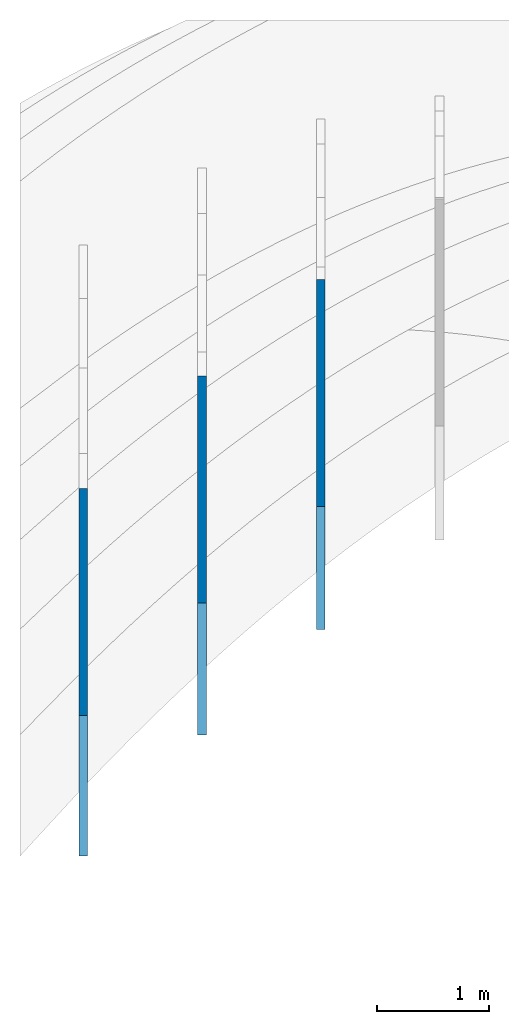
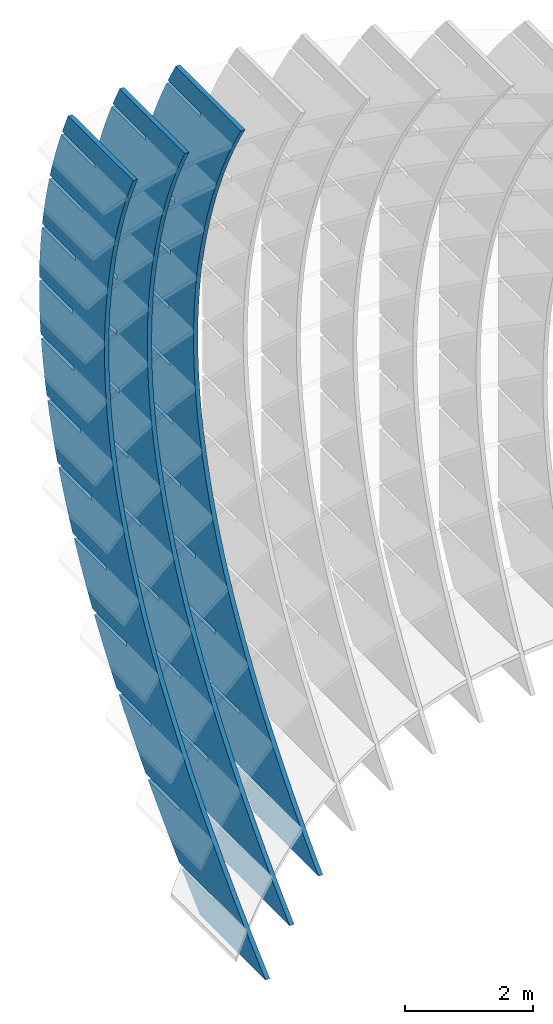
# Not in any storey, part 5 of 9: 3 walls.
"""IFC2X3 building model written with IfcOpenShell, lengths in metres."""

import ifcopenshell
import ifcopenshell.guid

model = None  # the IFC model being written
_history = None  # IfcOwnerHistory: only IFC2X3 demands one
_inside = {}  # id of a spatial element -> (the spatial element, [elements in it])
_under = {}  # id of a project, library or spatial element -> (it, [spatial elements below it])
_declared = {}  # id of a project -> (the project, [libraries it declares])
_typed = {}  # id of a type object -> (the type object, [elements of that type])
_made_of = {}  # id of a material, layer set ... -> (it, [elements and type objects made of it])


def new_model(schema):
    """Start an empty IFC model of exactly this schema.

    Asked for "IFC4X3", IfcOpenShell would pick the latest addendum, in which some entities
    have other attributes; the version numbers below select the first issue.
    IFC2X3 requires an IfcOwnerHistory on every rooted entity: one is made here for all.
    """
    global model, _history
    if schema == "IFC4X3":
        model = ifcopenshell.file(schema_version=(4, 3, 0, 0))
    else:
        model = ifcopenshell.file(schema=schema)
    _inside.clear()
    _under.clear()
    _declared.clear()
    _typed.clear()
    _made_of.clear()
    _history = None
    if model.schema == "IFC2X3":
        org = make("IfcOrganization", Name="unknown")
        user = make(
            "IfcPersonAndOrganization",
            ThePerson=make("IfcPerson", FamilyName="unknown"),
            TheOrganization=org,
        )
        app = make(
            "IfcApplication",
            ApplicationDeveloper=org,
            Version="unknown",
            ApplicationFullName="unknown",
            ApplicationIdentifier="unknown",
        )
        _history = make(
            "IfcOwnerHistory",
            OwningUser=user,
            OwningApplication=app,
            ChangeAction="ADDED",
            CreationDate=0,
        )
    return model


def make(cls, **values):
    """One entity of the class cls with the attributes given. An attribute that is None is left unset."""
    return model.create_entity(
        cls, **{name: value for name, value in values.items() if value is not None}
    )


def rooted(cls, **values):
    """An entity with a GlobalId (a new one), such as an element, a storey or a relation."""
    return make(cls, GlobalId=ifcopenshell.guid.new(), OwnerHistory=_history, **values)


def si_unit(unit_type, name, prefix=None):
    """IfcSIUnit, for example si_unit("LENGTHUNIT", "METRE", prefix="MILLI")."""
    return make("IfcSIUnit", UnitType=unit_type, Prefix=prefix, Name=name)


def assignment(units):
    """IfcUnitAssignment: the units of a project."""
    return None if units is None else make("IfcUnitAssignment", Units=units)


def point(xyz):
    """IfcCartesianPoint."""
    return None if xyz is None else make("IfcCartesianPoint", Coordinates=xyz)


def direction(xyz):
    """IfcDirection."""
    return None if xyz is None else make("IfcDirection", DirectionRatios=xyz)


def frame(location, z_axis=None, x_axis=None):
    """IfcAxis2Placement3D, a coordinate frame: its origin and axes. An axis left out is left unset."""
    return make(
        "IfcAxis2Placement3D",
        Location=point(location),
        Axis=direction(z_axis),
        RefDirection=direction(x_axis),
    )


def frame_2d(location, x_axis=None):
    """IfcAxis2Placement2D, a coordinate frame in the plane: its origin and x axis."""
    return make(
        "IfcAxis2Placement2D", Location=point(location), RefDirection=direction(x_axis)
    )


def origin_with_axes():
    """The frame at (0, 0, 0) with the z axis (0, 0, 1) and the x axis (1, 0, 0) written out."""
    return frame((0.0, 0.0, 0.0), z_axis=(0.0, 0.0, 1.0), x_axis=(1.0, 0.0, 0.0))


def place(relative_to, where):
    """IfcLocalPlacement: puts the frame where relative to a parent placement (None: the world)."""
    return make(
        "IfcLocalPlacement", PlacementRelTo=relative_to, RelativePlacement=where
    )


def context(
    kind, dimensions, precision=None, world=None, true_north=None, identifier=None
):
    """IfcGeometricRepresentationContext, for example the 3D "Model" context."""
    return make(
        "IfcGeometricRepresentationContext",
        ContextIdentifier=identifier,
        ContextType=kind,
        CoordinateSpaceDimension=dimensions,
        Precision=precision,
        WorldCoordinateSystem=world,
        TrueNorth=true_north,
    )


def project(units=None, contexts=None):
    """IfcProject with its units and contexts."""
    return rooted(
        "IfcProject",
        Name="project",
        RepresentationContexts=contexts,
        UnitsInContext=assignment(units),
    )


def spatial(cls, under=None, at=None, **own):
    """A site, building, storey or space (cls), placed at a placement, below another one or the project."""
    s = rooted(cls, ObjectPlacement=at, **own)
    if under is not None:
        _under.setdefault(under.id(), (under, []))[1].append(s)
    return s


def polyline(points):
    """IfcPolyline through the points."""
    return make("IfcPolyline", Points=[point(p) for p in points])


def circle_curve(where, radius):
    """IfcCircle in the frame where."""
    return make("IfcCircle", Position=where, Radius=radius)


def parameter(value):
    """IfcParameterValue: where a trimmed curve begins or ends, as a parameter of its basis curve."""
    return model.create_entity("IfcParameterValue", value)


def trimmed(basis, trim1, trim2, sense, master):
    """IfcTrimmedCurve: the piece of a basis curve between two trims."""
    return make(
        "IfcTrimmedCurve",
        BasisCurve=basis,
        Trim1=trim1,
        Trim2=trim2,
        SenseAgreement=sense,
        MasterRepresentation=master,
    )


def segment(curve, same_sense, transition):
    """IfcCompositeCurveSegment."""
    return make(
        "IfcCompositeCurveSegment",
        Transition=transition,
        SameSense=same_sense,
        ParentCurve=curve,
    )


def composite_curve(segments, self_intersect=None):
    """IfcCompositeCurve: segments joined end to end."""
    return make("IfcCompositeCurve", Segments=segments, SelfIntersect=self_intersect)


def outline(outer, holes=None, kind="AREA"):
    """IfcArbitraryClosedProfileDef: a profile drawn as a closed curve; with holes, ...WithVoids."""
    if holes is None:
        return make("IfcArbitraryClosedProfileDef", ProfileType=kind, OuterCurve=outer)
    return make(
        "IfcArbitraryProfileDefWithVoids",
        ProfileType=kind,
        OuterCurve=outer,
        InnerCurves=holes,
    )


def extrude(swept, where, along, depth):
    """IfcExtrudedAreaSolid: the profile swept, set in the frame where, extruded along a direction by depth."""
    return make(
        "IfcExtrudedAreaSolid",
        SweptArea=swept,
        Position=where,
        ExtrudedDirection=direction(along),
        Depth=depth,
    )


def shape(context_of_items, identifier, shape_type, items):
    """IfcShapeRepresentation: the items that make up one representation, for example the "Body"."""
    return make(
        "IfcShapeRepresentation",
        ContextOfItems=context_of_items,
        RepresentationIdentifier=identifier,
        RepresentationType=shape_type,
        Items=items,
    )


def material(Name=None, Category=None):
    """IfcMaterial."""
    return make("IfcMaterial", Name=Name, Category=Category)


def made_of(thing, what):
    """Note that an element or type object is made of a material, layer set ...; save() writes the relation."""
    if what is not None:
        _made_of.setdefault(what.id(), (what, []))[1].append(thing)
    return thing


def type_object(cls, material=None, **own):
    """A type object (cls), such as IfcWallType, which elements share."""
    return made_of(rooted(cls, **own), material)


def element(
    cls,
    number,
    at=None,
    inside=None,
    cuts=None,
    type_object=None,
    material=None,
    context=None,
    identifier="Body",
    shape_type=None,
    held_by="IfcProductDefinitionShape",
    body=None,
    shapes=None,
    **own,
):
    """One element of the class cls, such as IfcWall. Its Tag is "e" and its number.

    at: its placement. inside: the storey or other place that contains it. cuts: it is an
    opening in that element (IfcRelVoidsElement). A single representation is given by context,
    identifier, shape_type and body (its items); several are given by shapes. held_by: the class
    of the entity that holds the representations. save() writes the other relations.
    """
    e = rooted(cls, Tag="e%d" % number, ObjectPlacement=at, **own)
    if body is not None:
        shapes = [shape(context, identifier, shape_type, body)]
    if shapes is not None:
        e.Representation = make(held_by, Representations=shapes)
    if inside is not None:
        _inside.setdefault(inside.id(), (inside, []))[1].append(e)
    if cuts is not None:
        rooted(
            "IfcRelVoidsElement", RelatingBuildingElement=cuts, RelatedOpeningElement=e
        )
    if type_object is not None:
        _typed.setdefault(type_object.id(), (type_object, []))[1].append(e)
    return made_of(e, material)


def aggregate(whole, parts):
    """IfcRelAggregates: a whole, such as a stair, and the parts it consists of."""
    return rooted("IfcRelAggregates", RelatingObject=whole, RelatedObjects=parts)


def save(model, path):
    """Write the relations noted so far, then the file.

    IfcRelAggregates (storeys below a building ...), IfcRelContainedInSpatialStructure (elements
    in a storey), IfcRelDefinesByType, IfcRelAssociatesMaterial and IfcRelDeclares: one each for
    every whole, place, type object, material and project.
    """
    for whole, parts in _under.values():
        aggregate(whole, parts)
    for where, things in _inside.values():
        rooted(
            "IfcRelContainedInSpatialStructure",
            RelatedElements=things,
            RelatingStructure=where,
        )
    for kind, things in _typed.values():
        rooted("IfcRelDefinesByType", RelatedObjects=things, RelatingType=kind)
    for what, things in _made_of.values():
        rooted("IfcRelAssociatesMaterial", RelatedObjects=things, RelatingMaterial=what)
    for by, libraries in _declared.values():
        rooted("IfcRelDeclares", RelatingContext=by, RelatedDefinitions=libraries)
    model.write(path)


model = new_model("IFC2X3")

# Units and contexts
model_context = context("Model", 3, precision=2.54e-06, world=origin_with_axes(), true_north=direction((0.0, 1.0)), identifier="Body")
ifc_project = project(units=[si_unit("LENGTHUNIT", "METRE"), si_unit("AREAUNIT", "SQUARE_METRE"), si_unit("VOLUMEUNIT", "CUBIC_METRE"), si_unit("PLANEANGLEUNIT", "RADIAN")], contexts=[model_context])

# Building
building_placement = place(None, origin_with_axes())
building = spatial("IfcBuilding", under=ifc_project, at=building_placement, Name="Building", CompositionType="ELEMENT")

# Walls
ifc_material = material(Name="MATERIAL")
wall_type = type_object("IfcWallType", Name="WALL", PredefinedType="NOTDEFINED", material=ifc_material)
wall_1_placement = place(None, origin_with_axes())
element("IfcWall", 1, at=wall_1_placement, inside=building, type_object=wall_type, context=model_context, shape_type="SweptSolid", body=[
    extrude(outline(composite_curve([segment(trimmed(circle_curve(frame_2d((0.0, 18.7805822100167), x_axis=(0.0, -1.0)), 18.7805822100167), [parameter(0.0), point((0.0, -18.7805822100167))], [parameter(0.126052209133476), point((2.36106969752059, 0.149006376753275))], True, "PARAMETER"), True, "CONTINUOUS"), segment(trimmed(circle_curve(frame_2d((0.612023447740593, 13.8996900337255), x_axis=(0.12618039, -0.99200731)), 13.8614740853198), [parameter(0.0), point((2.36106969752059, 0.149006376753275))], [parameter(0.132468982160638), point((4.1619623028227, 0.500496104866536))], True, "PARAMETER"), True, "CONTINUOUS"), segment(trimmed(circle_curve(frame_2d((1.72975506601918, 9.99412499664391), x_axis=(0.24817844, -0.96871433)), 9.8002357919363), [parameter(0.0), point((4.1619623028227, 0.500496104866536))], [parameter(0.334546876266629), point((7.14426826936329, 1.82542446667211))], True, "PARAMETER"), True, "CONTINUOUS"), segment(trimmed(circle_curve(frame_2d((2.66424414609159, 8.46623394967241), x_axis=(0.55925653, -0.82899465)), 8.01067829428963), [parameter(0.0), point((7.14426826936329, 1.82542446667211))], [parameter(0.382825992074898), point((9.30060191048526, 3.9796180359157))], True, "PARAMETER"), True, "CONTINUOUS"), segment(trimmed(circle_curve(frame_2d((0.983061193487189, 9.49088818215723), x_axis=(0.83360849, -0.55235576)), 9.97775436677883), [parameter(0.0), point((9.30060191048526, 3.9796180359157))], [parameter(0.358478780963706), point((10.7054991826305, 7.24817068968568))], True, "PARAMETER"), True, "CONTINUOUS"), segment(polyline([(10.7054991826305, 7.24817068968568), (12.1394789142586, 5.80847414899383)]), True, "CONTINUOUS"), segment(polyline([(12.1394789142586, 5.80847414899383), (12.0165847078578, 5.35045726668352)]), True, "CONTINUOUS"), segment(polyline([(12.0165847078578, 5.35045726668352), (11.301586753306, 6.06830568466718)]), True, "CONTINUOUS"), segment(polyline([(11.301586753306, 6.06830568466718), (11.2457985123542, 6.01273897006659)]), True, "CONTINUOUS"), segment(polyline([(11.2457985123542, 6.01273897006659), (11.9915295046199, 5.26403499178051)]), True, "CONTINUOUS"), segment(trimmed(circle_curve(frame_2d((1.6196912771569, 8.29347713858481), x_axis=(0.92663826, -0.37595418)), 10.8052092963301), [parameter(0.101248118094021), point((11.9915295046199, 5.26403499178051))], [parameter(0.0), point((11.6322115704196, 4.23121356829538))], False, "PARAMETER"), True, "CONTINUOUS"), segment(polyline([(11.6322115704196, 4.23121356829538), (10.9134889446627, 4.95280150653243)]), True, "CONTINUOUS"), segment(polyline([(10.9134889446627, 4.95280150653243), (10.8577007037109, 4.89723479193184)]), True, "CONTINUOUS"), segment(polyline([(10.8577007037109, 4.89723479193184), (11.599707124098, 4.15227023417666)]), True, "CONTINUOUS"), segment(polyline([(11.599707124098, 4.15227023417666), (11.3591132952024, 3.62000755173173)]), True, "CONTINUOUS"), segment(polyline([(11.3591132952024, 3.62000755173173), (11.0492376676411, 3.31136239166556)]), True, "CONTINUOUS"), segment(polyline([(11.0492376676411, 3.31136239166556), (10.371831523561, 3.99146913290104)]), True, "CONTINUOUS"), segment(polyline([(10.371831523561, 3.99146913290104), (10.3160432826092, 3.93590241830045)]), True, "CONTINUOUS"), segment(polyline([(10.3160432826092, 3.93590241830045), (10.9934494266893, 3.25579567706497)]), True, "CONTINUOUS"), segment(polyline([(10.9934494266893, 3.25579567706497), (10.2966690213705, 2.56178207740538)]), True, "CONTINUOUS"), segment(polyline([(10.2966690213705, 2.56178207740538), (9.7010783933434, 3.15974713083424)]), True, "CONTINUOUS"), segment(polyline([(9.7010783933434, 3.15974713083424), (9.6452901523916, 3.10418041623365)]), True, "CONTINUOUS"), segment(polyline([(9.6452901523916, 3.10418041623365), (10.2408807804187, 2.50621536280479)]), True, "CONTINUOUS"), segment(polyline([(10.2408807804187, 2.50621536280479), (9.5441003750998, 1.8122017631452)]), True, "CONTINUOUS"), segment(polyline([(9.5441003750998, 1.8122017631452), (8.98017152573526, 2.37837881273609)]), True, "CONTINUOUS"), segment(polyline([(8.98017152573526, 2.37837881273609), (8.92438328478346, 2.3228120981355)]), True, "CONTINUOUS"), segment(polyline([(8.92438328478346, 2.3228120981355), (9.488312134148, 1.75663504854461)]), True, "CONTINUOUS"), segment(polyline([(9.488312134148, 1.75663504854461), (8.79153172882915, 1.06262144888503)]), True, "CONTINUOUS"), segment(polyline([(8.79153172882915, 1.06262144888503), (8.20911092073662, 1.6473641786066)]), True, "CONTINUOUS"), segment(polyline([(8.20911092073662, 1.6473641786066), (8.15332267978482, 1.59179746400601)]), True, "CONTINUOUS"), segment(polyline([(8.15332267978482, 1.59179746400601), (8.73574348787735, 1.00705473428444)]), True, "CONTINUOUS"), segment(polyline([(8.73574348787735, 1.00705473428444), (8.03896308255849, 0.313041134624849)]), True, "CONTINUOUS"), segment(polyline([(8.03896308255849, 0.313041134624849), (7.38789657834748, 0.966703228445765)]), True, "CONTINUOUS"), segment(polyline([(7.38789657834748, 0.966703228445765), (7.33210833739568, 0.911136513845174)]), True, "CONTINUOUS"), segment(polyline([(7.33210833739568, 0.911136513845174), (7.98317484160672, 0.257474420024233)]), True, "CONTINUOUS"), segment(polyline([(7.98317484160672, 0.257474420024233), (7.47568268066652, -0.248002569174215)]), True, "CONTINUOUS"), segment(polyline([(7.47568268066652, -0.248002569174215), (7.21812612255528, -0.36799870242229)]), True, "CONTINUOUS"), segment(polyline([(7.21812612255528, -0.36799870242229), (6.47709598664597, 0.375985678727636)]), True, "CONTINUOUS"), segment(polyline([(6.47709598664597, 0.375985678727636), (6.42130774569417, 0.320418964127045)]), True, "CONTINUOUS"), segment(polyline([(6.42130774569417, 0.320418964127045), (7.14100665592885, -0.402149150715125)]), True, "CONTINUOUS"), segment(trimmed(circle_curve(frame_2d((2.94970931545133, 9.20499495426867), x_axis=(0.30354679, -0.95281653)), 10.4816120539838), [parameter(0.102963694064158), point((7.14100665592885, -0.402149150715125))], [parameter(0.0), point((6.13136905284452, -0.782058293094637))], False, "PARAMETER"), True, "CONTINUOUS"), segment(polyline([(6.13136905284452, -0.782058293094637), (5.38662099857636, -0.0343411714592445)]), True, "CONTINUOUS"), segment(polyline([(5.38662099857636, -0.0343411714592445), (5.33083275762455, -0.0899078860598354)]), True, "CONTINUOUS"), segment(polyline([(5.33083275762455, -0.0899078860598354), (6.0468137495005, -0.808743260416502)]), True, "CONTINUOUS"), segment(trimmed(circle_curve(frame_2d((2.3932786925911, 10.9791527347436), x_axis=(0.20670972, -0.97840232)), 12.3411024793078), [parameter(0.0923396645129988), point((6.0468137495005, -0.808743260416502))], [parameter(0.0), point((4.9443045083521, -1.09541051582983))], False, "PARAMETER"), True, "CONTINUOUS"), segment(polyline([(4.9443045083521, -1.09541051582983), (4.19583853572574, -0.343960653708814)]), True, "CONTINUOUS"), segment(polyline([(4.19583853572574, -0.343960653708814), (4.14005029477394, -0.399527368309406)]), True, "CONTINUOUS"), segment(polyline([(4.14005029477394, -0.399527368309406), (4.85231336829116, -1.11463000218057)]), True, "CONTINUOUS"), segment(trimmed(circle_curve(frame_2d((1.88917419705349, 13.4072784761228), x_axis=(0.11927281, -0.99286152)), 14.8211342211162), [parameter(0.0817255920081606), point((4.85231336829116, -1.11463000218057))], [parameter(0.0), point((3.65693248907916, -1.30805537062757))], False, "PARAMETER"), True, "CONTINUOUS"), segment(polyline([(3.65693248907916, -1.30805537062757), (2.90474859809413, -0.552872768021075)]), True, "CONTINUOUS"), segment(polyline([(2.90474859809413, -0.552872768021075), (2.84896035714233, -0.608439482621667)]), True, "CONTINUOUS"), segment(polyline([(2.84896035714233, -0.608439482621667), (3.55750551230081, -1.31980937600733)]), True, "CONTINUOUS"), segment(trimmed(circle_curve(frame_2d((1.52536283143346, 16.4955452097451), x_axis=(0.04148146, -0.99913927)), 17.9308801482663), [parameter(0.0720826690361271), point((3.55750551230081, -1.31980937600733))], [parameter(0.0), point((2.26916186358017, -1.4199013627317))], False, "PARAMETER"), True, "CONTINUOUS"), segment(polyline([(2.26916186358017, -1.4199013627317), (1.51320838838461, -0.660934147812912)]), True, "CONTINUOUS"), segment(polyline([(1.51320838838461, -0.660934147812912), (1.45742014743281, -0.716500862413503)]), True, "CONTINUOUS"), segment(polyline([(1.45742014743281, -0.716500862413503), (2.16220040061956, -1.42409084439233)]), True, "CONTINUOUS"), segment(polyline([(2.16220040061956, -1.42409084439233), (1.43397973162894, -1.43969654069169)]), True, "CONTINUOUS"), segment(polyline([(1.43397973162894, -1.43969654069169), (0.0, 0.0)]), True, "CONTINUOUS")], self_intersect="UNKNOWN")), frame((8.83892916800323, -3.01816534739246, -6.51240052652949), z_axis=(1.0, 0.0, 0.0), x_axis=(0.0, 0.70569869, 0.70851208)), (0.0, 0.0, 1.0), 0.07874),
])
wall_2_placement = place(None, origin_with_axes())
element("IfcWall", 2, at=wall_2_placement, inside=building, type_object=wall_type, context=model_context, shape_type="SweptSolid", body=[
    extrude(outline(composite_curve([segment(trimmed(circle_curve(frame_2d((0.0, 20.7498428760674), x_axis=(0.0, -1.0)), 20.7498428760674), [parameter(0.0), point((0.0, -20.7498428760674))], [parameter(0.117942931703561), point((2.44162737702879, 0.144153488589276))], True, "PARAMETER"), True, "CONTINUOUS"), segment(trimmed(circle_curve(frame_2d((0.643578207575471, 15.2695852685844), x_axis=(0.11804474, -0.99300828)), 15.2319292063434), [parameter(0.0), point((2.44162737702879, 0.144153488589276))], [parameter(0.124395073727061), point((4.30441412826717, 0.48412120049268))], True, "PARAMETER"), True, "CONTINUOUS"), segment(trimmed(circle_curve(frame_2d((1.8672400111281, 10.7110313416443), x_axis=(0.23181815, -0.97275914)), 10.5133015134373), [parameter(0.0), point((4.30441412826717, 0.48412120049268))], [parameter(0.319204423434442), point((7.39062087934888, 1.76554239486139))], True, "PARAMETER"), True, "CONTINUOUS"), segment(trimmed(circle_curve(frame_2d((3.10873744701453, 8.59550003558826), x_axis=(0.53117237, -0.84726378)), 8.06119390054741), [parameter(0.0), point((7.39062087934888, 1.76554239486139))], [parameter(0.381220152494694), point((9.62433862857443, 3.84894461664728))], True, "PARAMETER"), True, "CONTINUOUS"), segment(trimmed(circle_curve(frame_2d((1.99735114064463, 9.28594601572767), x_axis=(0.81428083, -0.58047113)), 9.36653203457074), [parameter(0.0), point((9.62433862857443, 3.84894461664728))], [parameter(0.373868508714165), point((11.083176042308, 7.01004878365571))], True, "PARAMETER"), True, "CONTINUOUS"), segment(polyline([(11.083176042308, 7.01004878365571), (12.5631916705325, 5.61772061105729)]), True, "CONTINUOUS"), segment(polyline([(12.5631916705325, 5.61772061105729), (12.4352539556502, 5.17476177161533)]), True, "CONTINUOUS"), segment(polyline([(12.4352539556502, 5.17476177161533), (11.69538336186, 5.8707967675749)]), True, "CONTINUOUS"), segment(polyline([(11.69538336186, 5.8707967675749), (11.6414306451718, 5.8134461619812)]), True, "CONTINUOUS"), segment(polyline([(11.6414306451718, 5.8134461619812), (12.4091836406182, 5.09118073128483)]), True, "CONTINUOUS"), segment(trimmed(circle_curve(frame_2d((2.84830963771117, 8.09681940900774), x_axis=(0.91670521, -0.39956421)), 10.0221841711519), [parameter(0.106455079224626), point((12.4091836406182, 5.09118073128483))], [parameter(0.0), point((12.0356981011496, 4.09231334928382))], False, "PARAMETER"), True, "CONTINUOUS"), segment(polyline([(12.0356981011496, 4.09231334928382), (11.291983260839, 4.79196482917137)]), True, "CONTINUOUS"), segment(polyline([(11.291983260839, 4.79196482917137), (11.2380305441508, 4.73461422357767)]), True, "CONTINUOUS"), segment(polyline([(11.2380305441508, 4.73461422357767), (12.001939395592, 4.01596518036797)]), True, "CONTINUOUS"), segment(trimmed(circle_curve(frame_2d((3.84526623502701, 7.65628704443192), x_axis=(0.86061154, -0.509262)), 8.93214757615793), [parameter(0.114554431580321), point((12.001939395592, 4.01596518036797))], [parameter(0.0), point((11.5323754975983, 3.10748373943453))], False, "PARAMETER"), True, "CONTINUOUS"), segment(polyline([(11.5323754975983, 3.10748373943453), (10.7848233804043, 3.81074514654769)]), True, "CONTINUOUS"), segment(polyline([(10.7848233804043, 3.81074514654769), (10.7308706637161, 3.753394540954)]), True, "CONTINUOUS"), segment(polyline([(10.7308706637161, 3.753394540954), (11.4909422382739, 3.03835542496998)]), True, "CONTINUOUS"), segment(polyline([(11.4909422382739, 3.03835542496998), (11.1500788557139, 2.52010468421222)]), True, "CONTINUOUS"), segment(polyline([(11.1500788557139, 2.52010468421222), (10.8949019281416, 2.24885696531814)]), True, "CONTINUOUS"), segment(polyline([(10.8949019281416, 2.24885696531814), (10.1575773813566, 2.94249676158748)]), True, "CONTINUOUS"), segment(polyline([(10.1575773813566, 2.94249676158748), (10.1036246646684, 2.88514615599379)]), True, "CONTINUOUS"), segment(polyline([(10.1036246646684, 2.88514615599379), (10.8409492114534, 2.19150635972444)]), True, "CONTINUOUS"), segment(polyline([(10.8409492114534, 2.19150635972444), (10.1670940197379, 1.47521243238261)]), True, "CONTINUOUS"), segment(polyline([(10.1670940197379, 1.47521243238261), (9.43656578216638, 2.16245858482337)]), True, "CONTINUOUS"), segment(polyline([(9.43656578216638, 2.16245858482337), (9.38261306547819, 2.10510797922967)]), True, "CONTINUOUS"), segment(polyline([(9.38261306547819, 2.10510797922967), (10.1131413030497, 1.41786182678891)]), True, "CONTINUOUS"), segment(polyline([(10.1131413030497, 1.41786182678891), (9.66684890927915, 0.943462378054507)]), True, "CONTINUOUS"), segment(polyline([(9.66684890927915, 0.943462378054507), (9.40124145896024, 0.737358496457015)]), True, "CONTINUOUS"), segment(polyline([(9.40124145896024, 0.737358496457015), (8.64217751435791, 1.45144968219767)]), True, "CONTINUOUS"), segment(polyline([(8.64217751435791, 1.45144968219767), (8.58822479766972, 1.39409907660397)]), True, "CONTINUOUS"), segment(polyline([(8.58822479766972, 1.39409907660397), (9.33678453834149, 0.689889745341289)]), True, "CONTINUOUS"), segment(trimmed(circle_curve(frame_2d((4.21680982461918, 7.7243986130785), x_axis=(0.49043217, -0.87147937)), 8.7004859680037), [parameter(0.116579561067315), point((9.33678453834149, 0.689889745341289))], [parameter(0.0), point((8.48380803568256, 0.142104610191828))], False, "PARAMETER"), True, "CONTINUOUS"), segment(polyline([(8.48380803568256, 0.142104610191828), (7.72090681095518, 0.859805726207812)]), True, "CONTINUOUS"), segment(polyline([(7.72090681095518, 0.859805726207812), (7.66695409426699, 0.802455120614112)]), True, "CONTINUOUS"), segment(polyline([(7.66695409426699, 0.802455120614112), (8.41167656129142, 0.101855713532831)]), True, "CONTINUOUS"), segment(trimmed(circle_curve(frame_2d((3.70306654380121, 8.65240523421223), x_axis=(0.38517224, -0.9228447)), 9.76129629723429), [parameter(0.10797008628847), point((8.41167656129142, 0.101855713532831))], [parameter(0.0), point((7.46284690827612, -0.355755344580128))], False, "PARAMETER"), True, "CONTINUOUS"), segment(polyline([(7.46284690827612, -0.355755344580128), (6.69610840666539, 0.365555698661541)]), True, "CONTINUOUS"), segment(polyline([(6.69610840666539, 0.365555698661541), (6.6421556899772, 0.308205093067843)]), True, "CONTINUOUS"), segment(polyline([(6.6421556899772, 0.308205093067843), (7.38304088011826, -0.388784386787757)]), True, "CONTINUOUS"), segment(trimmed(circle_curve(frame_2d((3.10306853715157, 10.1110500172022), x_axis=(0.2853332, -0.95842838)), 11.3386368566848), [parameter(0.0977064081270978), point((7.38304088011826, -0.388784386787757))], [parameter(0.0), point((6.33835807609852, -0.756221368336648))], False, "PARAMETER"), True, "CONTINUOUS"), segment(polyline([(6.33835807609852, -0.756221368336648), (5.56778229760459, -0.0313003978692463)]), True, "CONTINUOUS"), segment(polyline([(5.56778229760459, -0.0313003978692463), (5.5138295809164, -0.0886510034629458)]), True, "CONTINUOUS"), segment(polyline([(5.5138295809164, -0.0886510034629458), (6.2508774941741, -0.782030556092863)]), True, "CONTINUOUS"), segment(trimmed(circle_curve(frame_2d((2.4950142771272, 12.183456297622), x_axis=(0.19374902, -0.98105113)), 13.4985316927071), [parameter(0.0869815694130255), point((6.2508774941741, -0.782030556092863))], [parameter(0.0), point((5.11034153915032, -1.05929346107757))], False, "PARAMETER"), True, "CONTINUOUS"), segment(polyline([(5.11034153915032, -1.05929346107757), (4.33592848377278, -0.330762563384555)]), True, "CONTINUOUS"), segment(polyline([(4.33592848377278, -0.330762563384555), (4.28197576708459, -0.388113168978255)]), True, "CONTINUOUS"), segment(polyline([(4.28197576708459, -0.388113168978255), (5.01518640345893, -1.07788279438249)]), True, "CONTINUOUS"), segment(trimmed(circle_curve(frame_2d((1.9571022363408, 14.9527474107897), x_axis=(0.11162545, -0.99375035)), 16.3197115032147), [parameter(0.076641680514835), point((5.01518640345893, -1.07788279438249))], [parameter(0.0), point((3.77879729743093, -1.26497162280308))], False, "PARAMETER"), True, "CONTINUOUS"), segment(polyline([(3.77879729743093, -1.26497162280308), (3.00054696516996, -0.532830797884383)]), True, "CONTINUOUS"), segment(polyline([(3.00054696516996, -0.532830797884383), (2.94659424848177, -0.590181403478082)]), True, "CONTINUOUS"), segment(polyline([(2.94659424848177, -0.590181403478082), (3.67596760797276, -1.27634110165663)]), True, "CONTINUOUS"), segment(trimmed(circle_curve(frame_2d((1.57487888946023, 18.4198545645324), x_axis=(0.03881031, -0.9992466)), 19.8079453130269), [parameter(0.067452899350918), point((3.67596760797276, -1.27634110165663))], [parameter(0.0), point((2.34363129384849, -1.37316736908379))], False, "PARAMETER"), True, "CONTINUOUS"), segment(polyline([(2.34363129384849, -1.37316736908379), (1.56149036019343, -0.637366451780404)]), True, "CONTINUOUS"), segment(polyline([(1.56149036019343, -0.637366451780404), (1.50753764350525, -0.694717057374104)]), True, "CONTINUOUS"), segment(polyline([(1.50753764350525, -0.694717057374104), (2.23302523415724, -1.37722120940601)]), True, "CONTINUOUS"), segment(polyline([(2.23302523415724, -1.37722120940601), (1.48001562822447, -1.39232817259843)]), True, "CONTINUOUS"), segment(polyline([(1.48001562822447, -1.39232817259843), (0.0, 0.0)]), True, "CONTINUOUS")], self_intersect="UNKNOWN")), frame((7.77674734982097, -3.96130133537658, -6.51240052652892), z_axis=(1.0, 0.0, 0.0), x_axis=(0.0, 0.72835415, 0.68520087)), (0.0, 0.0, 1.0), 0.07874),
])
wall_3_placement = place(None, origin_with_axes())
element("IfcWall", 3, at=wall_3_placement, inside=building, type_object=wall_type, context=model_context, shape_type="SweptSolid", body=[
    extrude(outline(composite_curve([segment(trimmed(circle_curve(frame_2d((0.0, 22.9365359536653), x_axis=(0.0, -1.0)), 22.9365359536653), [parameter(0.0), point((0.0, -22.9365359536653))], [parameter(0.110318939486029), point((2.52520496952262, 0.139430404590012))], True, "PARAMETER"), True, "CONTINUOUS"), segment(trimmed(circle_curve(frame_2d((0.672488936910521, 16.8183420515482), x_axis=(0.11040231, -0.99388698)), 16.7814972640862), [parameter(0.0), point((2.52520496952262, 0.139430404590012))], [parameter(0.11661089629043), point((4.45316043807532, 0.46826029564204))], True, "PARAMETER"), True, "CONTINUOUS"), segment(trimmed(circle_curve(frame_2d((1.99399653770527, 11.5614089966964), x_axis=(0.21642888, -0.97629839)), 11.3624572691204), [parameter(0.0), point((4.45316043807532, 0.46826029564204))], [parameter(0.303056968094618), point((7.6517240000857, 1.70770131105778))], True, "PARAMETER"), True, "CONTINUOUS"), segment(trimmed(circle_curve(frame_2d((3.5214644626633, 8.81256725956293), x_axis=(0.50257712, -0.86453238)), 8.21816062100861), [parameter(0.0), point((7.6517240000857, 1.70770131105778))], [parameter(0.376335826421515), point((9.9738243953056, 3.72285063755646))], True, "PARAMETER"), True, "CONTINUOUS"), segment(trimmed(circle_curve(frame_2d((2.94394484330167, 9.1453583360203), x_axis=(0.79181179, -0.61076516)), 8.87822033155196), [parameter(0.0), point((9.9738243953056, 3.72285063755646))], [parameter(0.387393373093524), point((11.5013832442308, 6.78039654565535))], True, "PARAMETER"), True, "CONTINUOUS"), segment(polyline([(11.5013832442308, 6.78039654565535), (13.0230206865761, 5.43368072780303)]), True, "CONTINUOUS"), segment(polyline([(13.0230206865761, 5.43368072780303), (12.8880437359984, 5.00523326898551)]), True, "CONTINUOUS"), segment(polyline([(12.8880437359984, 5.00523326898551), (12.1253934986852, 5.68021214995682)]), True, "CONTINUOUS"), segment(polyline([(12.1253934986852, 5.68021214995682), (12.0732082607434, 5.62124869906594)]), True, "CONTINUOUS"), segment(polyline([(12.0732082607434, 5.62124869906594), (12.8605798330632, 4.92439035327262)]), True, "CONTINUOUS"), segment(trimmed(circle_curve(frame_2d((3.99545259155274, 7.96078149208688), x_axis=(0.90418895, -0.42713271)), 9.37070713212402), [parameter(0.111332939286555), point((12.8605798330632, 4.92439035327262))], [parameter(0.0), point((12.4683424042981, 3.95824599853841))], False, "PARAMETER"), True, "CONTINUOUS"), segment(polyline([(12.4683424042981, 3.95824599853841), (11.701739810448, 4.6367228882456)]), True, "CONTINUOUS"), segment(polyline([(11.701739810448, 4.6367228882456), (11.6495545725062, 4.57775943735472)]), True, "CONTINUOUS"), segment(polyline([(11.6495545725062, 4.57775943735472), (12.4329738936872, 3.88439900701525)]), True, "CONTINUOUS"), segment(trimmed(circle_curve(frame_2d((4.7640271979427, 7.59316623999463), x_axis=(0.84261169, -0.53852162)), 8.51866760770671), [parameter(0.118233031779909), point((12.4329738936872, 3.88439900701525))], [parameter(0.0), point((11.9419561379154, 3.00567957044521))], False, "PARAMETER"), True, "CONTINUOUS"), segment(polyline([(11.9419561379154, 3.00567957044521), (11.1714083531693, 3.68764812698194)]), True, "CONTINUOUS"), segment(polyline([(11.1714083531693, 3.68764812698194), (11.1192231152275, 3.62868467609105)]), True, "CONTINUOUS"), segment(polyline([(11.1192231152275, 3.62868467609105), (11.8986972455125, 2.93881591258115)]), True, "CONTINUOUS"), segment(trimmed(circle_curve(frame_2d((5.17614642397355, 7.33093650973202), x_axis=(0.76374406, -0.64551918)), 8.03015646722349), [parameter(0.122982293439989), point((11.8986972455125, 2.93881591258115))], [parameter(0.0), point((11.3091307036649, 2.14731647030494))], False, "PARAMETER"), True, "CONTINUOUS"), segment(polyline([(11.3091307036649, 2.14731647030494), (10.5346377280228, 2.83277669367116)]), True, "CONTINUOUS"), segment(polyline([(10.5346377280228, 2.83277669367116), (10.482452490081, 2.77381324278027)]), True, "CONTINUOUS"), segment(polyline([(10.482452490081, 2.77381324278027), (11.25798142947, 2.08743614609992)]), True, "CONTINUOUS"), segment(trimmed(circle_curve(frame_2d((5.22119910824393, 7.29736571936513), x_axis=(0.67075581, -0.74167826)), 7.97408972562079), [parameter(0.123558271913986), point((11.25798142947, 2.08743614609992))], [parameter(0.0), point((10.5698661015465, 1.38315669811752))], False, "PARAMETER"), True, "CONTINUOUS"), segment(polyline([(10.5698661015465, 1.38315669811752), (9.79142793500836, 2.07210858831326)]), True, "CONTINUOUS"), segment(polyline([(9.79142793500836, 2.07210858831326), (9.7392426970666, 2.01314513742237)]), True, "CONTINUOUS"), segment(polyline([(9.7392426970666, 2.01314513742237), (10.5108264455596, 1.33025970757158)]), True, "CONTINUOUS"), segment(trimmed(circle_curve(frame_2d((4.974821959162, 7.57791484440299), x_axis=(0.5689545, -0.822369)), 8.34748706990257), [parameter(0.119844445167167), point((10.5108264455596, 1.33025970757158))], [parameter(0.0), point((9.72416233156021, 0.713200253882925))], False, "PARAMETER"), True, "CONTINUOUS"), segment(polyline([(9.72416233156021, 0.713200253882925), (8.9417789741261, 1.40564381090824)]), True, "CONTINUOUS"), segment(polyline([(8.9417789741261, 1.40564381090824), (8.88959373618434, 1.34668036001736)]), True, "CONTINUOUS"), segment(polyline([(8.88959373618434, 1.34668036001736), (9.65723229378141, 0.667286596996128)]), True, "CONTINUOUS"), segment(trimmed(circle_curve(frame_2d((4.51265168513427, 8.25804486035624), x_axis=(0.46449651, -0.88557495)), 9.16985935833467), [parameter(0.112565458213446), point((9.65723229378141, 0.667286596996128))], [parameter(0.0), point((8.77201939370613, 0.13744713760127))], False, "PARAMETER"), True, "CONTINUOUS"), segment(polyline([(8.77201939370613, 0.13744713760127), (7.98569084537598, 0.833382361456112)]), True, "CONTINUOUS"), segment(polyline([(7.98569084537598, 0.833382361456112), (7.93350560743422, 0.774418910565229)]), True, "CONTINUOUS"), segment(polyline([(7.93350560743422, 0.774418910565229), (8.69719897413531, 0.098516814373555)]), True, "CONTINUOUS"), segment(trimmed(circle_curve(frame_2d((3.91032499456817, 9.42321674273461), x_axis=(0.36283658, -0.93185279)), 10.4816120539845), [parameter(0.102963694064151), point((8.69719897413531, 0.098516814373555))], [parameter(0.0), point((7.713437287984, -0.344102650727601))], False, "PARAMETER"), True, "CONTINUOUS"), segment(polyline([(7.713437287984, -0.344102650727601), (6.923163548758, 0.355324239956863)]), True, "CONTINUOUS"), segment(polyline([(6.923163548758, 0.355324239956863), (6.87097831081623, 0.29636078906598)]), True, "CONTINUOUS"), segment(polyline([(6.87097831081623, 0.29636078906598), (7.63072648662136, -0.376049640296135)]), True, "CONTINUOUS"), segment(trimmed(circle_curve(frame_2d((3.24347859587104, 11.1588914670479), x_axis=(0.2677992, -0.96347475)), 12.3411024793082), [parameter(0.0923396645129957), point((7.63072648662136, -0.376049640296135))], [parameter(0.0), point((6.54841601439357, -0.731449111103675))], False, "PARAMETER"), True, "CONTINUOUS"), segment(polyline([(6.54841601439357, -0.731449111103675), (5.75419708427215, -0.028530553589502)]), True, "CONTINUOUS"), segment(polyline([(5.75419708427215, -0.028530553589502), (5.70201184633039, -0.0874940044803853)]), True, "CONTINUOUS"), segment(polyline([(5.70201184633039, -0.0874940044803853), (6.45781483123954, -0.756412767012942)]), True, "CONTINUOUS"), segment(trimmed(circle_curve(frame_2d((2.58774919745029, 13.5505300088051), x_axis=(0.18144403, -0.98340127)), 14.8211342211171), [parameter(0.0817255920081554), point((6.45781483123954, -0.756412767012942))], [parameter(0.0), point((5.27695557293652, -1.02459224352653))], False, "PARAMETER"), True, "CONTINUOUS"), segment(polyline([(5.27695557293652, -1.02459224352653), (4.47879145191844, -0.318182019182984)]), True, "CONTINUOUS"), segment(polyline([(4.47879145191844, -0.318182019182984), (4.42660621397668, -0.377145470073867)]), True, "CONTINUOUS"), segment(polyline([(4.42660621397668, -0.377145470073867), (5.17846400798986, -1.04257256577687)]), True, "CONTINUOUS"), segment(trimmed(circle_curve(frame_2d((2.01877350771265, 16.6835933435182), x_axis=(0.10442781, -0.99453247)), 18.0055714127988), [parameter(0.0717788694798388), point((5.17846400798986, -1.04257256577687))], [parameter(0.0), point((3.89905596360999, -1.22353204799681))], False, "PARAMETER"), True, "CONTINUOUS"), segment(polyline([(3.89905596360999, -1.22353204799681), (3.09694665169687, -0.513630156823584)]), True, "CONTINUOUS"), segment(polyline([(3.09694665169687, -0.513630156823584), (3.04476141375511, -0.572593607714467)]), True, "CONTINUOUS"), segment(polyline([(3.04476141375511, -0.572593607714467), (3.79267401687231, -1.23452903658791)]), True, "CONTINUOUS"), segment(trimmed(circle_curve(frame_2d((1.61978677161066, 20.5526426643695), x_axis=(0.03630164, -0.99934088)), 21.8952572423258), [parameter(0.0630940933256505), point((3.79267401687231, -1.23452903658791))], [parameter(0.0), point((2.41462048419952, -1.3281829388145))], False, "PARAMETER"), True, "CONTINUOUS"), segment(polyline([(2.41462048419952, -1.3281829388145), (1.60851115725819, -0.614740859052003)]), True, "CONTINUOUS"), segment(polyline([(1.60851115725819, -0.614740859052003), (1.55632591931642, -0.673704309942887)]), True, "CONTINUOUS"), segment(polyline([(1.55632591931642, -0.673704309942887), (2.30024347586456, -1.3321039475313)]), True, "CONTINUOUS"), segment(polyline([(2.30024347586456, -1.3321039475313), (1.52163744234582, -1.34671581785194)]), True, "CONTINUOUS"), segment(polyline([(1.52163744234582, -1.34671581785194), (0.0, 0.0)]), True, "CONTINUOUS")], self_intersect="UNKNOWN")), frame((6.71456553163902, -5.04677891185152, -6.51240052652922), z_axis=(1.0, 0.0, 0.0), x_axis=(0.0, 0.74883732, 0.66275385)), (0.0, 0.0, 1.0), 0.07874),
])

save(model, "model.ifc")
